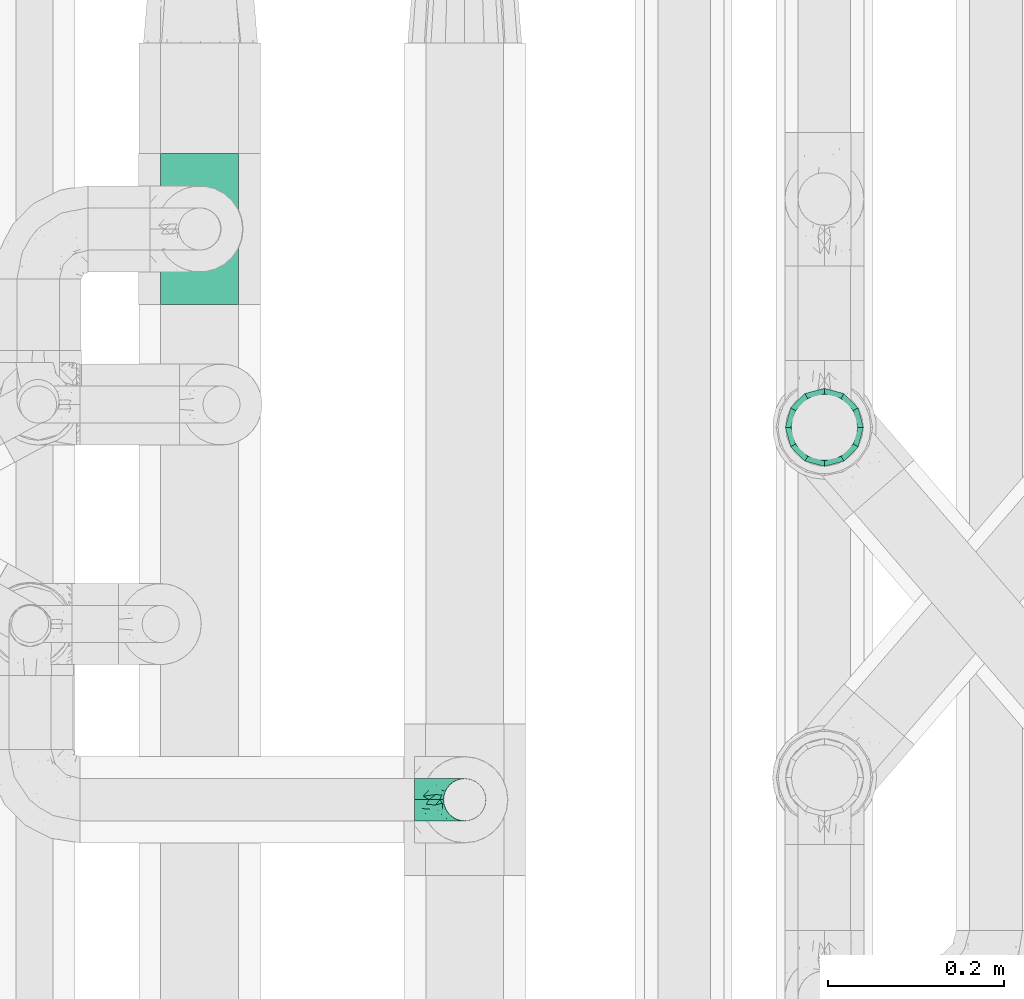
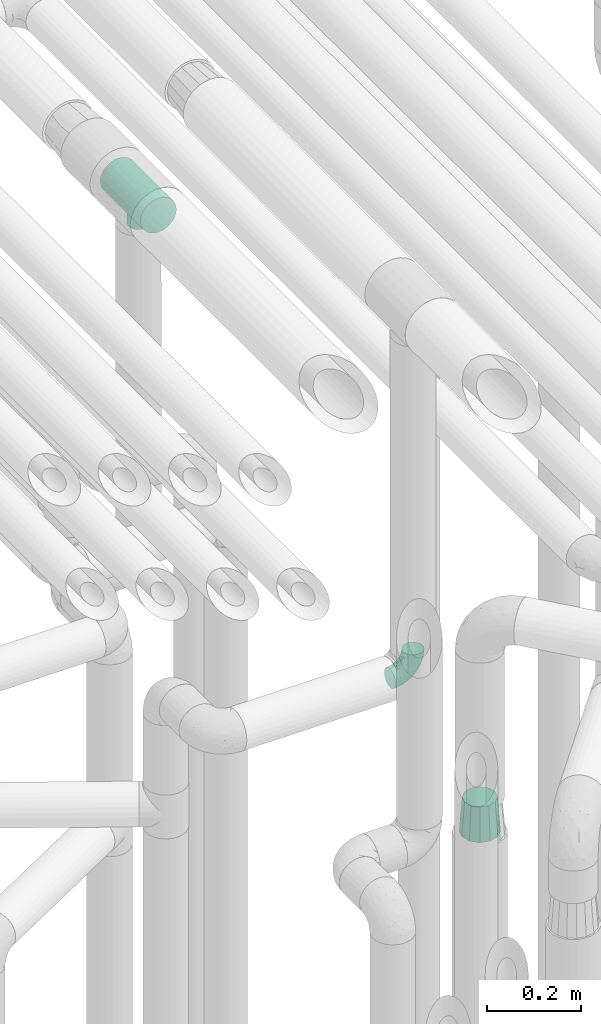
# One storey, part 624 of 827: 3 flow fittings.
"""IFC2X3 building model written with IfcOpenShell, lengths in millimetres."""

from ifc_helpers import new_model, entity, si_unit, converted_unit, derived_unit, direction, frame, origin, place, context, subcontext, project, spatial, faceted_brep, source, transform, mapped, material, type_object, type_shapes, element, save


model = new_model("IFC2X3")

# Units and contexts
model_context = context("Model", 3, precision=0.01, world=origin(), true_north=direction((6.12303176911189e-17, 1.0)))
body_context = subcontext(model_context, "Body", "Model", "MODEL_VIEW")
ifc_project = project(units=[si_unit("LENGTHUNIT", "METRE", prefix="MILLI"), si_unit("AREAUNIT", "SQUARE_METRE"), si_unit("VOLUMEUNIT", "CUBIC_METRE"), converted_unit("PLANEANGLEUNIT", "DEGREE", entity("IfcRatioMeasure", 0.0174532925199433), si_unit("PLANEANGLEUNIT", "RADIAN"), dimensions=[0, 0, 0, 0, 0, 0, 0]), si_unit("MASSUNIT", "GRAM", prefix="KILO"), derived_unit("MASSDENSITYUNIT", [(si_unit("MASSUNIT", "GRAM", prefix="KILO"), 1), (si_unit("LENGTHUNIT", "METRE"), -3)]), derived_unit("MOMENTOFINERTIAUNIT", [(si_unit("LENGTHUNIT", "METRE"), 4)]), si_unit("TIMEUNIT", "SECOND"), si_unit("FREQUENCYUNIT", "HERTZ"), si_unit("THERMODYNAMICTEMPERATUREUNIT", "DEGREE_CELSIUS"), derived_unit("THERMALTRANSMITTANCEUNIT", [(si_unit("MASSUNIT", "GRAM", prefix="KILO"), 1), (si_unit("THERMODYNAMICTEMPERATUREUNIT", "KELVIN"), -1), (si_unit("TIMEUNIT", "SECOND"), -3)]), derived_unit("VOLUMETRICFLOWRATEUNIT", [(si_unit("LENGTHUNIT", "METRE"), 3), (si_unit("TIMEUNIT", "SECOND"), -1)]), derived_unit("MASSFLOWRATEUNIT", [(si_unit("MASSUNIT", "GRAM", prefix="KILO"), 1), (si_unit("TIMEUNIT", "SECOND"), -1)]), derived_unit("ROTATIONALFREQUENCYUNIT", [(si_unit("TIMEUNIT", "SECOND"), -1)]), si_unit("ELECTRICCURRENTUNIT", "AMPERE"), si_unit("ELECTRICVOLTAGEUNIT", "VOLT"), si_unit("POWERUNIT", "WATT"), si_unit("FORCEUNIT", "NEWTON", prefix="KILO"), si_unit("ILLUMINANCEUNIT", "LUX"), si_unit("LUMINOUSFLUXUNIT", "LUMEN"), si_unit("LUMINOUSINTENSITYUNIT", "CANDELA"), derived_unit("USERDEFINED", [(si_unit("MASSUNIT", "GRAM", prefix="KILO"), -1), (si_unit("LENGTHUNIT", "METRE"), -2), (si_unit("TIMEUNIT", "SECOND"), 3), (si_unit("LUMINOUSFLUXUNIT", "LUMEN"), 1)]), derived_unit("LINEARVELOCITYUNIT", [(si_unit("LENGTHUNIT", "METRE"), 1), (si_unit("TIMEUNIT", "SECOND"), -1)]), si_unit("PRESSUREUNIT", "PASCAL"), derived_unit("USERDEFINED", [(si_unit("LENGTHUNIT", "METRE"), -2), (si_unit("MASSUNIT", "GRAM", prefix="KILO"), 1), (si_unit("TIMEUNIT", "SECOND"), -2)]), derived_unit("LINEARFORCEUNIT", [(si_unit("MASSUNIT", "GRAM", prefix="KILO"), 1), (si_unit("LENGTHUNIT", "METRE"), 1), (si_unit("TIMEUNIT", "SECOND"), -2), (si_unit("LENGTHUNIT", "METRE"), -1)]), derived_unit("PLANARFORCEUNIT", [(si_unit("MASSUNIT", "GRAM", prefix="KILO"), 1), (si_unit("LENGTHUNIT", "METRE"), 1), (si_unit("TIMEUNIT", "SECOND"), -2), (si_unit("LENGTHUNIT", "METRE"), -2)])], contexts=[model_context])

# Site, building, storey
site_placement = place(None, origin())
site = spatial("IfcSite", under=ifc_project, at=site_placement, CompositionType="ELEMENT")
building_placement = place(site_placement, origin())
building = spatial("IfcBuilding", under=site, at=building_placement, CompositionType="ELEMENT")
storey_placement = place(building_placement, frame((0.0, 0.0, 28200.0)))
storey = spatial("IfcBuildingStorey", under=building, at=storey_placement, Name="08", CompositionType="ELEMENT", Elevation=28200.0)

# Flow fittings
ifc_material = material()
pipe_fitting_type_1 = type_object("IfcPipeFittingType", Name="ADSK_1", PredefinedType="NOTDEFINED", material=ifc_material)
shared_shape_1 = source(origin(), body_context, "Body", "Brep", [
    faceted_brep([(-57.0, 12.07, -20.91), (-57.0, 6.25, -23.33), (-57.0, 0.0, -24.15), (-57.0, -6.25, -23.33), (-57.0, -12.08, -20.91), (-57.0, -17.08, -17.08), (-57.0, -20.91, -12.08), (-57.0, -23.33, -6.25), (-57.0, -24.15, 0.0), (-57.0, -23.33, 6.25), (-57.0, -20.91, 12.07), (-57.0, -17.08, 17.08), (-57.0, -12.08, 20.91), (-57.0, -6.25, 23.33), (-57.0, 0.0, 24.15), (-57.0, 6.25, 23.33), (-57.0, 12.07, 20.91), (-57.0, 17.08, 17.08), (-57.0, 20.91, 12.07), (-57.0, 23.33, 6.25), (-57.0, 24.15, 0.0), (-57.0, 23.33, -6.25), (-57.0, 20.91, -12.08), (-57.0, 17.08, -17.08), (0.0, 57.0, -24.15), (-6.25, 57.0, -23.33), (-12.07, 57.0, -20.91), (-17.08, 57.0, -17.08), (-20.91, 57.0, -12.08), (-23.33, 57.0, -6.25), (-24.15, 57.0, 0.0), (-23.33, 57.0, 6.25), (-20.91, 57.0, 12.07), (-17.08, 57.0, 17.08), (-12.07, 57.0, 20.91), (-6.25, 57.0, 23.33), (0.0, 57.0, 24.15), (6.25, 57.0, 23.33), (12.08, 57.0, 20.91), (17.08, 57.0, 17.08), (20.91, 57.0, 12.07), (23.33, 57.0, 6.25), (24.15, 57.0, 0.0), (23.33, 57.0, -6.25), (20.91, 57.0, -12.08), (17.08, 57.0, -17.08), (12.08, 57.0, -20.91), (6.25, 57.0, -23.33), (14.9, 21.14, 6.17), (13.61, 24.64, 12.48), (6.23, 8.95, 8.98), (-41.47, -21.06, 0.0), (-41.92, -18.38, 13.72), (-24.64, -13.61, 12.48), (-37.37, -13.24, 18.15), (-6.8, -4.93, 8.18), (-21.76, -15.19, 6.22), (-12.78, -9.18, 0.0), (-37.73, -20.51, 7.75), (-7.38, 7.38, 20.24), (-23.37, -4.26, 20.42), (-11.9, -3.19, 15.86), (-42.14, -8.7, 21.82), (13.24, 37.37, 18.15), (9.33, 23.53, 16.85), (4.26, 23.37, 20.42), (2.77, 10.92, 15.55), (-29.46, 0.91, 23.52), (-44.13, 20.56, 15.69), (-39.25, 26.33, 10.88), (-49.02, 22.92, 9.96), (-34.58, 23.87, 17.15), (-15.8, 6.8, 22.81), (-8.67, 20.47, 23.88), (-18.12, 12.9, 24.08), (-48.29, 14.92, 19.65), (-44.06, -2.85, 23.78), (-9.23, 48.95, 22.58), (-3.78, 42.74, 24.07), (-40.34, 4.26, 24.09), (-44.02, 26.14, 5.46), (-44.04, 9.88, 22.74), (-4.95, 16.87, 22.52), (-2.75, 1.43, 12.5), (-25.48, 40.98, 10.71), (20.51, 37.73, 7.75), (18.38, 41.92, 13.72), (8.7, 42.14, 21.82), (-25.95, -17.97, 0.0), (2.85, 44.06, 23.78), (21.06, 41.47, 0.0), (17.97, 25.95, 0.0), (-24.04, -9.27, 17.13), (-33.26, 33.26, 5.86), (-28.55, 40.57, 0.0), (-40.57, 28.55, 0.0), (-25.29, 47.19, 4.06), (-27.01, 31.1, 16.77), (-15.7, 43.95, 19.9), (-20.27, 45.22, 15.61), (-30.53, 31.98, 12.64), (-11.28, 38.33, 22.92), (-9.97, 27.88, 24.09), (-20.15, 30.26, 21.25), (-31.25, 11.75, 23.64), (-28.75, 7.23, 24.15), (-29.53, 18.06, 22.27), (-28.44, 24.21, 20.02), (-37.55, 17.7, 20.26), (-15.88, 29.25, 22.99), (-20.82, 20.82, 23.44), (-0.91, 29.46, 23.52), (-13.5, -7.67, 12.04), (1.49, 1.56, 5.16), (8.86, 10.35, 4.59), (0.38, -0.38, 0.0), (9.18, 12.78, 0.0), (-37.37, -13.24, -18.15), (8.86, 10.35, -4.59), (-45.22, 20.27, -15.61), (-43.95, 15.7, -19.9), (-38.33, 11.28, -22.92), (-48.95, 9.23, -22.58), (-47.19, 25.29, -4.06), (-33.26, 33.26, -5.86), (18.38, 41.92, -13.72), (-30.26, 20.15, -21.25), (2.85, 44.06, -23.78), (-4.26, 40.34, -24.09), (-40.98, 25.48, -10.71), (-41.92, -18.38, -13.72), (9.25, 23.5, -16.92), (4.26, 23.37, -20.42), (13.24, 37.37, -18.15), (-37.73, -20.51, -7.75), (-11.75, 31.25, -23.64), (-7.23, 28.75, -24.15), (-12.9, 18.12, -24.08), (8.7, 42.14, -21.82), (-44.06, -2.85, -23.78), (-6.8, 15.8, -22.81), (-20.47, 8.67, -23.88), (-24.64, -13.61, -12.48), (-42.74, 3.78, -24.07), (-18.06, 29.53, -22.27), (-24.21, 28.44, -20.02), (-27.88, 9.97, -24.09), (-31.1, 27.01, -16.77), (-26.14, 44.02, -5.46), (14.9, 21.14, -6.17), (20.51, 37.73, -7.75), (-9.88, 44.04, -22.74), (-20.56, 44.13, -15.69), (-21.76, -15.19, -6.22), (-13.5, -7.67, -12.04), (-24.14, -9.76, -16.74), (-11.9, -3.19, -15.86), (-14.92, 48.29, -19.65), (-23.37, -4.26, -20.42), (-0.91, 29.46, -23.52), (-26.33, 39.25, -10.88), (-23.87, 34.58, -17.15), (-42.14, -8.7, -21.82), (-22.92, 49.02, -9.96), (13.61, 24.64, -12.48), (-31.98, 30.53, -12.64), (-16.87, 4.95, -22.52), (-17.7, 37.55, -20.26), (-29.25, 15.88, -22.99), (-20.82, 20.82, -23.44), (-29.46, 0.91, -23.52), (-7.38, 7.38, -20.24), (2.77, 10.92, -15.55), (6.23, 8.95, -8.98), (-6.8, -4.93, -8.18), (-2.81, 1.41, -12.54), (1.49, 1.56, -5.16)], [[[0, 1, 2, 3, 4, 5, 6, 7, 8, 9, 10, 11, 12, 13, 14, 15, 16, 17, 18, 19, 20, 21, 22, 23]], [[24, 25, 26, 27, 28, 29, 30, 31, 32, 33, 34, 35, 36, 37, 38, 39, 40, 41, 42, 43, 44, 45, 46, 47]], [[48, 49, 50]], [[9, 8, 51]], [[52, 53, 54]], [[55, 56, 57]], [[10, 58, 52]], [[9, 58, 10]], [[59, 60, 61]], [[54, 12, 11]], [[54, 62, 12]], [[63, 39, 38]], [[64, 65, 66]], [[62, 60, 67]], [[68, 69, 70]], [[71, 69, 68]], [[72, 73, 74]], [[16, 75, 17]], [[13, 76, 14]], [[35, 77, 78]], [[14, 79, 15]], [[17, 68, 18]], [[14, 76, 79]], [[20, 19, 80]], [[70, 19, 18]], [[81, 15, 79]], [[15, 81, 16]], [[73, 72, 82]], [[66, 83, 50]], [[32, 31, 84]], [[85, 86, 49]], [[63, 87, 65]], [[56, 58, 88]], [[36, 89, 37]], [[85, 41, 40]], [[36, 35, 78]], [[90, 41, 85]], [[40, 39, 86]], [[12, 62, 13]], [[86, 85, 40]], [[48, 85, 49]], [[85, 91, 90]], [[87, 38, 37]], [[92, 60, 54]], [[80, 69, 93]], [[93, 94, 95]], [[10, 52, 11]], [[94, 96, 30]], [[97, 98, 99]], [[80, 93, 95]], [[100, 97, 84]], [[99, 98, 33]], [[101, 102, 78]], [[103, 101, 98]], [[96, 31, 30]], [[77, 98, 101]], [[77, 35, 34]], [[34, 33, 98]], [[9, 51, 58]], [[87, 63, 38]], [[104, 105, 74]], [[106, 103, 107]], [[106, 81, 104]], [[75, 68, 17]], [[108, 107, 71]], [[33, 32, 99]], [[109, 103, 110]], [[101, 109, 102]], [[89, 78, 111]], [[53, 52, 58]], [[54, 11, 52]], [[60, 62, 54]], [[88, 58, 51]], [[76, 62, 67]], [[53, 112, 92]], [[60, 59, 72]], [[39, 63, 86]], [[49, 86, 63]], [[89, 87, 37]], [[42, 41, 90]], [[111, 82, 65]], [[111, 65, 87]], [[65, 59, 66]], [[104, 81, 79]], [[75, 81, 108]], [[32, 84, 99]], [[97, 99, 84]], [[98, 97, 103]], [[106, 107, 108]], [[74, 102, 110]], [[111, 78, 102]], [[74, 110, 104]], [[74, 67, 72]], [[61, 92, 112]], [[66, 59, 61]], [[56, 53, 58]], [[66, 50, 49]], [[61, 112, 83]], [[66, 49, 64]], [[78, 89, 36]], [[87, 89, 111]], [[62, 76, 13]], [[79, 76, 67]], [[100, 93, 69]], [[96, 93, 84]], [[55, 113, 50]], [[113, 114, 50]], [[104, 79, 105]], [[106, 104, 110]], [[20, 80, 95]], [[85, 48, 91]], [[115, 114, 113]], [[116, 91, 48]], [[70, 80, 19]], [[93, 96, 94]], [[84, 31, 96]], [[103, 106, 110]], [[81, 106, 108]], [[103, 97, 107]], [[71, 107, 97]], [[71, 97, 100]], [[108, 71, 68]], [[79, 67, 105]], [[67, 74, 105]], [[115, 113, 57]], [[112, 56, 55]], [[56, 88, 57]], [[60, 72, 67]], [[82, 72, 59]], [[65, 82, 59]], [[82, 111, 73]], [[111, 102, 73]], [[102, 74, 73]], [[81, 75, 16]], [[68, 75, 108]], [[68, 70, 18]], [[80, 70, 69]], [[98, 77, 34]], [[78, 77, 101]], [[93, 100, 84]], [[71, 100, 69]], [[102, 109, 110]], [[101, 103, 109]], [[53, 92, 54]], [[61, 60, 92]], [[56, 112, 53]], [[83, 112, 55]], [[50, 83, 55]], [[61, 83, 66]], [[49, 63, 64]], [[65, 64, 63]], [[57, 113, 55]], [[114, 115, 116]], [[116, 48, 114]], [[48, 50, 114]], [[117, 5, 4]], [[116, 115, 118]], [[119, 120, 23]], [[121, 122, 120]], [[95, 123, 20]], [[0, 23, 120]], [[124, 95, 94]], [[125, 45, 44]], [[121, 120, 126]], [[24, 127, 128]], [[22, 21, 129]], [[0, 122, 1]], [[5, 117, 130]], [[131, 132, 133]], [[134, 88, 51]], [[135, 136, 137]], [[6, 5, 130]], [[46, 138, 47]], [[139, 3, 2]], [[140, 141, 137]], [[6, 134, 7]], [[134, 130, 142]], [[143, 2, 1]], [[144, 126, 145]], [[121, 146, 143]], [[147, 120, 119]], [[94, 148, 124]], [[149, 150, 91]], [[30, 29, 148]], [[151, 25, 128]], [[27, 152, 28]], [[134, 153, 88]], [[154, 155, 156]], [[27, 26, 157]], [[151, 26, 25]], [[155, 158, 156]], [[24, 47, 127]], [[1, 122, 143]], [[138, 132, 159]], [[160, 152, 161]], [[24, 128, 25]], [[46, 133, 138]], [[162, 117, 4]], [[148, 160, 124]], [[152, 160, 163]], [[154, 142, 155]], [[45, 125, 133]], [[133, 46, 45]], [[125, 164, 133]], [[51, 7, 134]], [[42, 90, 43]], [[165, 147, 129]], [[153, 134, 142]], [[43, 150, 44]], [[162, 4, 3]], [[141, 140, 166]], [[117, 162, 158]], [[163, 29, 28]], [[43, 90, 150]], [[123, 21, 20]], [[144, 151, 135]], [[157, 152, 27]], [[167, 145, 161]], [[23, 22, 119]], [[168, 126, 169]], [[121, 168, 146]], [[139, 143, 170]], [[142, 130, 117]], [[8, 7, 51]], [[134, 6, 130]], [[139, 162, 3]], [[170, 166, 158]], [[170, 158, 162]], [[158, 171, 156]], [[44, 150, 125]], [[91, 150, 90]], [[164, 125, 150]], [[132, 138, 133]], [[127, 138, 159]], [[131, 164, 172]], [[132, 171, 140]], [[135, 151, 128]], [[157, 151, 167]], [[22, 129, 119]], [[147, 119, 129]], [[120, 147, 126]], [[144, 145, 167]], [[137, 146, 169]], [[170, 143, 146]], [[137, 169, 135]], [[137, 159, 140]], [[171, 172, 156]], [[173, 174, 175]], [[156, 175, 154]], [[174, 57, 153]], [[132, 172, 171]], [[172, 164, 173]], [[143, 139, 2]], [[162, 139, 170]], [[138, 127, 47]], [[128, 127, 159]], [[165, 124, 160]], [[123, 124, 129]], [[149, 173, 164]], [[176, 174, 173]], [[135, 128, 136]], [[144, 135, 169]], [[150, 149, 164]], [[176, 118, 115]], [[149, 91, 116]], [[30, 148, 94]], [[163, 148, 29]], [[124, 123, 95]], [[129, 21, 123]], [[126, 144, 169]], [[151, 144, 167]], [[126, 147, 145]], [[161, 145, 147]], [[161, 147, 165]], [[167, 161, 152]], [[128, 159, 136]], [[159, 137, 136]], [[154, 153, 142]], [[132, 140, 159]], [[174, 176, 57]], [[57, 88, 153]], [[166, 140, 171]], [[158, 166, 171]], [[166, 170, 141]], [[170, 146, 141]], [[146, 137, 141]], [[151, 157, 26]], [[152, 157, 167]], [[152, 163, 28]], [[148, 163, 160]], [[120, 122, 0]], [[143, 122, 121]], [[124, 165, 129]], [[161, 165, 160]], [[146, 168, 169]], [[121, 126, 168]], [[142, 117, 155]], [[158, 155, 117]], [[175, 156, 172]], [[153, 154, 174]], [[173, 175, 172]], [[174, 154, 175]], [[164, 131, 133]], [[172, 132, 131]], [[176, 173, 118]], [[57, 176, 115]], [[173, 149, 118]], [[149, 116, 118]]]),
])
type_shapes(pipe_fitting_type_1, [shared_shape_1])
flow_fitting_1_placement = place(storey_placement, frame((36220.03, 12556.08, 2600.0), z_axis=(0.0, -1.0, 0.0), x_axis=(1.0, 0.0, 0.0)))
element("IfcFlowFitting", 1, at=flow_fitting_1_placement, inside=storey, type_object=pipe_fitting_type_1, material=ifc_material, Name="ADSK_1", ObjectType="ADSK_1", context=body_context, shape_type="MappedRepresentation", body=[
    mapped(shared_shape_1, transform((0.0, 0.0, 0.0), scale=1.0)),
])
pipe_fitting_type_2 = type_object("IfcPipeFittingType", Name="ADSK_1", PredefinedType="NOTDEFINED", material=ifc_material)
shared_shape_2 = source(origin(), body_context, "Body", "Brep", [
    faceted_brep([(89.0, -44.45, 0.0), (89.0, -41.96, -9.31), (89.0, -38.49, -22.22), (89.0, -30.36, -30.36), (89.0, -22.23, -38.49), (89.0, -11.11, -41.47), (89.0, 0.0, -44.45), (89.0, 11.11, -41.47), (89.0, 22.22, -38.49), (89.0, 30.36, -30.36), (89.0, 38.49, -22.22), (89.0, 41.96, -9.31), (89.0, 44.45, 0.0), (89.0, 41.96, 9.31), (89.0, 38.49, 22.23), (89.0, 30.36, 30.36), (89.0, 22.22, 38.49), (89.0, 11.11, 41.47), (89.0, 0.0, 44.45), (89.0, -11.11, 41.47), (89.0, -22.23, 38.49), (89.0, -30.36, 30.36), (89.0, -38.49, 22.23), (89.0, -41.96, 9.31), (0.0, 38.05, 0.0), (0.0, 35.5, -9.51), (0.0, 32.95, -19.02), (0.0, 25.99, -25.99), (0.0, 19.02, -32.95), (0.0, 9.51, -35.5), (0.0, 0.0, -38.05), (0.0, -9.51, -35.5), (0.0, -19.03, -32.95), (0.0, -25.99, -25.99), (0.0, -32.95, -19.02), (0.0, -35.5, -9.51), (0.0, -38.05, 0.0), (0.0, -35.5, 9.51), (0.0, -32.95, 19.03), (0.0, -25.99, 25.99), (0.0, -19.03, 32.95), (0.0, -9.51, 35.5), (0.0, 0.0, 38.05), (0.0, 9.51, 35.5), (0.0, 19.03, 32.95), (0.0, 25.99, 25.99), (0.0, 32.95, 19.03), (0.0, 35.5, 9.51)], [[[0, 1, 2, 3, 4, 5, 6, 7, 8, 9, 10, 11, 12, 13, 14, 15, 16, 17, 18, 19, 20, 21, 22, 23]], [[24, 25, 26, 27, 28, 29, 30, 31, 32, 33, 34, 35, 36, 37, 38, 39, 40, 41, 42, 43, 44, 45, 46, 47]], [[2, 1, 0, 36, 35, 34]], [[28, 8, 7, 6, 30, 29]], [[32, 4, 3, 2, 34, 33]], [[5, 4, 32, 31, 30, 6]], [[10, 26, 25, 24, 12, 11]], [[9, 8, 28, 27, 26, 10]], [[14, 13, 12, 24, 47, 46]], [[40, 20, 19, 18, 42, 41]], [[44, 16, 15, 14, 46, 45]], [[17, 16, 44, 43, 42, 18]], [[22, 38, 37, 36, 0, 23]], [[21, 20, 40, 39, 38, 22]]]),
])
type_shapes(pipe_fitting_type_2, [shared_shape_2])
flow_fitting_2_placement = place(storey_placement, frame((36629.64, 12980.2, 1870.0), z_axis=(0.0, 1.0, 0.0), x_axis=(0.0, 0.0, -1.0)))
element("IfcFlowFitting", 2, at=flow_fitting_2_placement, inside=storey, type_object=pipe_fitting_type_2, material=ifc_material, Name="ADSK_1", ObjectType="ADSK_1", context=body_context, shape_type="MappedRepresentation", body=[
    mapped(shared_shape_2, transform((0.0, 0.0, 0.0), scale=1.0)),
])
pipe_fitting_type_3 = type_object("IfcPipeFittingType", Name="ADSK_1", PredefinedType="NOTDEFINED", material=ifc_material)
shared_shape_3 = source(origin(), body_context, "Body", "Brep", [
    faceted_brep([(-86.0, 22.22, -38.49), (-86.0, 11.5, -42.94), (-86.0, 0.0, -44.45), (-86.0, -11.5, -42.94), (-86.0, -22.23, -38.49), (-86.0, -31.43, -31.43), (-86.0, -38.49, -22.23), (-86.0, -42.94, -11.5), (-86.0, -44.45, 0.0), (-86.0, -42.94, 11.5), (-86.0, -38.49, 22.22), (-86.0, -31.43, 31.43), (-86.0, -22.23, 38.49), (-86.0, -11.5, 42.94), (-86.0, 0.0, 44.45), (-86.0, 11.5, 42.94), (-86.0, 22.22, 38.49), (-86.0, 31.43, 31.43), (-86.0, 38.49, 22.22), (-86.0, 42.94, 11.5), (-86.0, 44.45, 0.0), (-86.0, 42.94, -11.5), (-86.0, 38.49, -22.23), (-86.0, 31.43, -31.43), (86.0, 0.0, -44.45), (86.0, 11.5, -42.94), (86.0, 22.22, -38.49), (86.0, 31.43, -31.43), (86.0, 38.49, -22.23), (86.0, 42.94, -11.5), (86.0, 44.45, 0.0), (86.0, 42.94, 11.5), (86.0, 38.49, 22.22), (86.0, 31.43, 31.43), (86.0, 22.22, 38.49), (86.0, 11.5, 42.94), (86.0, 0.0, 44.45), (86.0, -11.5, 42.94), (86.0, -22.23, 38.49), (86.0, -31.43, 31.43), (86.0, -38.49, 22.22), (86.0, -42.94, 11.5), (86.0, -44.45, 0.0), (86.0, -42.94, -11.5), (86.0, -38.49, -22.23), (86.0, -31.43, -31.43), (86.0, -22.23, -38.49), (86.0, -11.5, -42.94), (22.65, -43.65, 8.39), (23.4, -44.05, 4.19), (24.15, -44.45, 0.0), (18.45, -41.63, 15.58), (4.27, -37.56, 23.77), (12.15, -39.25, 20.87), (8.21, -38.4, 22.32), (-24.15, -44.45, 0.0), (-23.4, -44.05, 4.19), (-22.65, -43.65, 8.38), (-18.46, -41.63, 15.57), (-12.16, -39.25, 20.87), (-8.22, -38.4, 22.32), (-4.28, -37.56, 23.77), (0.0, -37.56, 23.77), (4.27, -37.56, -23.77), (12.15, -39.25, -20.87), (8.21, -38.4, -22.32), (18.45, -41.63, -15.58), (22.65, -43.65, -8.39), (23.4, -44.05, -4.19), (-4.28, -37.56, -23.77), (-8.22, -38.4, -22.32), (-12.16, -39.25, -20.87), (-18.46, -41.63, -15.57), (0.0, -37.56, -23.77), (-22.65, -43.65, -8.38), (-23.4, -44.05, -4.19), (0.0, -73.0, -24.15), (6.25, -73.0, -23.33), (12.08, -73.0, -20.91), (17.08, -73.0, -17.08), (20.91, -73.0, -12.08), (23.33, -73.0, -6.25), (24.15, -73.0, 0.0), (23.33, -73.0, 6.25), (20.91, -73.0, 12.07), (17.08, -73.0, 17.08), (12.08, -73.0, 20.91), (6.25, -73.0, 23.33), (0.0, -73.0, 24.15), (-6.25, -73.0, 23.33), (-12.07, -73.0, 20.91), (-17.08, -73.0, 17.08), (-20.91, -73.0, 12.07), (-23.33, -73.0, 6.25), (-24.15, -73.0, 0.0), (-23.33, -73.0, -6.25), (-20.91, -73.0, -12.08), (-17.08, -73.0, -17.08), (-12.07, -73.0, -20.91), (-6.25, -73.0, -23.33)], [[[0, 1, 2, 3, 4, 5, 6, 7, 8, 9, 10, 11, 12, 13, 14, 15, 16, 17, 18, 19, 20, 21, 22, 23]], [[24, 25, 26, 27, 28, 29, 30, 31, 32, 33, 34, 35, 36, 37, 38, 39, 40, 41, 42, 43, 44, 45, 46, 47]], [[42, 41, 48]], [[42, 48, 49, 50]], [[41, 51, 48]], [[40, 39, 52]], [[53, 51, 40]], [[40, 52, 54, 53]], [[39, 11, 52]], [[40, 51, 41]], [[8, 55, 56, 57]], [[9, 8, 57]], [[57, 58, 9]], [[10, 59, 60, 61]], [[59, 10, 58]], [[10, 61, 11]], [[58, 10, 9]], [[11, 61, 62, 52]], [[39, 38, 12, 11]], [[14, 13, 37, 36]], [[13, 12, 38, 37]], [[15, 14, 36, 35]], [[32, 31, 19, 18]], [[17, 16, 34, 33]], [[18, 17, 33, 32]], [[35, 34, 16, 15]], [[20, 19, 31, 30]], [[29, 28, 22, 21]], [[28, 27, 23, 22]], [[30, 29, 21, 20]], [[24, 47, 3, 2]], [[1, 0, 26, 25]], [[2, 1, 25, 24]], [[27, 26, 0, 23]], [[4, 3, 47, 46]], [[46, 45, 5, 4]], [[45, 44, 63]], [[44, 64, 65, 63]], [[44, 66, 64]], [[45, 63, 5]], [[43, 42, 67]], [[67, 66, 43]], [[42, 50, 68, 67]], [[43, 66, 44]], [[6, 69, 70, 71]], [[6, 5, 69]], [[71, 72, 6]], [[5, 63, 73, 69]], [[72, 74, 7]], [[74, 8, 7]], [[8, 74, 75, 55]], [[72, 7, 6]], [[76, 77, 78, 79, 80, 81, 82, 83, 84, 85, 86, 87, 88, 89, 90, 91, 92, 93, 94, 95, 96, 97, 98, 99]], [[93, 56, 94]], [[88, 61, 89]], [[60, 90, 89]], [[60, 59, 90]], [[86, 54, 87]], [[93, 57, 56]], [[49, 82, 50]], [[57, 93, 92]], [[56, 55, 94]], [[57, 92, 58]], [[90, 59, 91]], [[89, 61, 60]], [[91, 59, 58]], [[91, 58, 92]], [[88, 52, 62, 61]], [[86, 53, 54]], [[85, 53, 86]], [[48, 84, 83]], [[85, 84, 51]], [[52, 88, 87]], [[54, 52, 87]], [[53, 85, 51]], [[51, 84, 48]], [[82, 49, 83]], [[49, 48, 83]], [[81, 68, 82]], [[79, 66, 80]], [[65, 64, 78]], [[81, 67, 68]], [[80, 67, 81]], [[64, 79, 78]], [[68, 50, 82]], [[67, 80, 66]], [[77, 63, 65]], [[64, 66, 79]], [[76, 69, 73, 63]], [[98, 70, 99]], [[75, 94, 55]], [[98, 71, 70]], [[76, 63, 77]], [[75, 74, 95]], [[97, 71, 98]], [[74, 96, 95]], [[97, 96, 72]], [[69, 76, 99]], [[70, 69, 99]], [[71, 97, 72]], [[72, 96, 74]], [[94, 75, 95]], [[65, 78, 77]]]),
])
type_shapes(pipe_fitting_type_3, [shared_shape_3])
flow_fitting_3_placement = place(storey_placement, frame((35918.07, 13206.08, 3550.0), z_axis=(1.0, 0.0, 0.0), x_axis=(0.0, 1.0, -9.11558797326423e-08)))
element("IfcFlowFitting", 3, at=flow_fitting_3_placement, inside=storey, type_object=pipe_fitting_type_3, material=ifc_material, Name="ADSK_1", ObjectType="ADSK_1", context=body_context, shape_type="MappedRepresentation", body=[
    mapped(shared_shape_3, transform((0.0, 0.0, 0.0), scale=1.0)),
])

save(model, "model.ifc")
